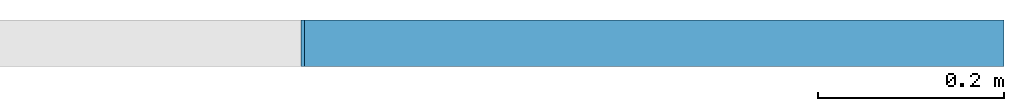
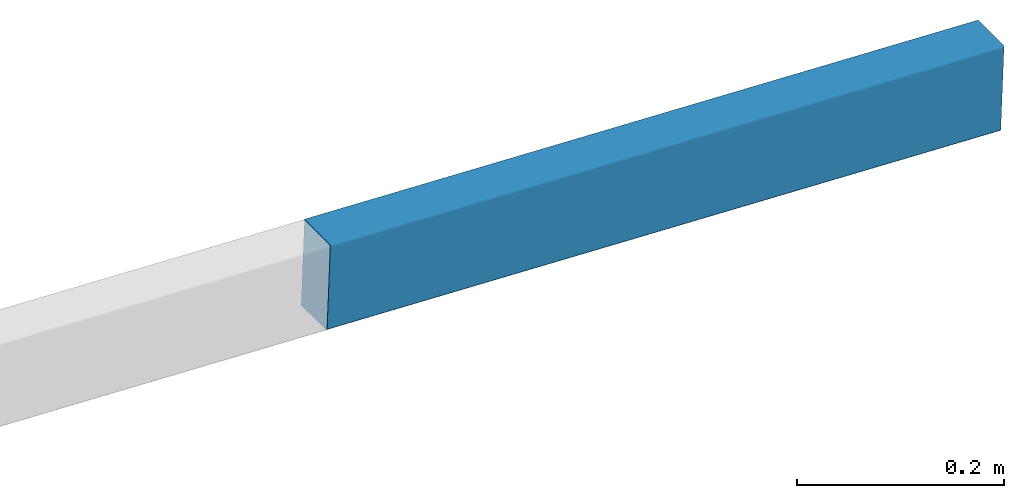
# One storey, part 2 of 2: 1 member.
"""IFC4 building model written with IfcOpenShell, lengths in metres."""

from ifc_helpers import new_model, entity, si_unit, derived_unit, frame, origin_with_axes, place, context, project, spatial, mirrored_profile, composite_profile, extrude, material, material_profile, profile_set, profile_usage, element, save


model = new_model("IFC4")

# Units and contexts
model_context = context("Model", 3, world=origin_with_axes())
ifc_project = project(units=[si_unit("LENGTHUNIT", "METRE"), si_unit("AREAUNIT", "SQUARE_METRE"), si_unit("VOLUMEUNIT", "CUBIC_METRE"), derived_unit("SECTIONMODULUSUNIT", [(si_unit("LENGTHUNIT", "METRE"), 3)]), derived_unit("MOMENTOFINERTIAUNIT", [(si_unit("LENGTHUNIT", "METRE"), 4)]), si_unit("PLANEANGLEUNIT", "RADIAN"), si_unit("TIMEUNIT", "SECOND"), si_unit("THERMODYNAMICTEMPERATUREUNIT", "DEGREE_CELSIUS"), derived_unit("THERMALEXPANSIONCOEFFICIENTUNIT", [(si_unit("THERMODYNAMICTEMPERATUREUNIT", "DEGREE_CELSIUS"), -1)])], contexts=[model_context])

# Site, building, storey
site = spatial("IfcSite", under=ifc_project, CompositionType="ELEMENT")
building = spatial("IfcBuilding", under=site, Name="Building", CompositionType="ELEMENT")
storey = spatial("IfcBuildingStorey", under=building, Name="LEVEL 4", CompositionType="ELEMENT", Elevation=6.5278)

# Member
ifc_material = material(Name="SAE 1020")
cartesian_point_1 = entity("IfcCartesianPoint", [0.0044999998, 0.050000001])
ifc_direction_1 = entity("IfcDirection", [1.0, 0.0])
cartesian_point_2 = entity("IfcCartesianPoint", [0.0015, 0.046999998])
cartesian_point_3 = entity("IfcCartesianPoint", [0.0015, -0.046999998])
cartesian_point_4 = entity("IfcCartesianPoint", [0.0044999998, -0.050000001])
cartesian_point_5 = entity("IfcCartesianPoint", [0.0044999998, 0.050000001])
ifc_direction_2 = entity("IfcDirection", [1.0, 0.0])
cartesian_point_6 = entity("IfcCartesianPoint", [0.0015, 0.046999998])
cartesian_point_7 = entity("IfcCartesianPoint", [0.0015, -0.046999998])
cartesian_point_8 = entity("IfcCartesianPoint", [0.0044999998, -0.050000001])
ifc_material_profile = material_profile(ifc_material, composite_profile([entity("IfcCenterLineProfileDef", "AREA", None, entity("IfcCompositeCurve", [entity("IfcCompositeCurveSegment", "CONTSAMEGRADIENT", True, entity("IfcPolyline", [entity("IfcCartesianPoint", [0.0515, 0.050000001]), cartesian_point_1])), entity("IfcCompositeCurveSegment", "CONTSAMEGRADIENT", True, entity("IfcTrimmedCurve", entity("IfcCircle", entity("IfcAxis2Placement2D", entity("IfcCartesianPoint", [0.0044999998, 0.047000002]), ifc_direction_1), 0.003), [cartesian_point_1], [cartesian_point_2], True, "CARTESIAN")), entity("IfcCompositeCurveSegment", "CONTSAMEGRADIENT", True, entity("IfcPolyline", [cartesian_point_2, cartesian_point_3])), entity("IfcCompositeCurveSegment", "CONTSAMEGRADIENT", True, entity("IfcTrimmedCurve", entity("IfcCircle", entity("IfcAxis2Placement2D", entity("IfcCartesianPoint", [0.0044999998, -0.047000002]), ifc_direction_1), 0.003), [cartesian_point_3], [cartesian_point_4], True, "CARTESIAN")), entity("IfcCompositeCurveSegment", "CONTSAMEGRADIENT", True, entity("IfcPolyline", [cartesian_point_4, entity("IfcCartesianPoint", [0.0515, -0.050000001])]))], "UNKNOWN"), 0.003), mirrored_profile(entity("IfcCenterLineProfileDef", "AREA", None, entity("IfcCompositeCurve", [entity("IfcCompositeCurveSegment", "CONTSAMEGRADIENT", True, entity("IfcPolyline", [entity("IfcCartesianPoint", [0.0515, 0.050000001]), cartesian_point_5])), entity("IfcCompositeCurveSegment", "CONTSAMEGRADIENT", True, entity("IfcTrimmedCurve", entity("IfcCircle", entity("IfcAxis2Placement2D", entity("IfcCartesianPoint", [0.0044999998, 0.047000002]), ifc_direction_2), 0.003), [cartesian_point_5], [cartesian_point_6], True, "CARTESIAN")), entity("IfcCompositeCurveSegment", "CONTSAMEGRADIENT", True, entity("IfcPolyline", [cartesian_point_6, cartesian_point_7])), entity("IfcCompositeCurveSegment", "CONTSAMEGRADIENT", True, entity("IfcTrimmedCurve", entity("IfcCircle", entity("IfcAxis2Placement2D", entity("IfcCartesianPoint", [0.0044999998, -0.047000002]), ifc_direction_2), 0.003), [cartesian_point_7], [cartesian_point_8], True, "CARTESIAN")), entity("IfcCompositeCurveSegment", "CONTSAMEGRADIENT", True, entity("IfcPolyline", [cartesian_point_8, entity("IfcCartesianPoint", [0.0515, -0.050000001])]))], "UNKNOWN"), 0.003))]))
ifc_profile_set = profile_set([ifc_material_profile])
ifc_profile_usage = profile_usage(ifc_profile_set, cardinal=10)
member_placement = place(None, frame((30.500014, 3.166, 6.5278), z_axis=(0.99929685, 0.0, -0.037494075), x_axis=(0.0, 1.0, 0.0)))
cartesian_point_9 = entity("IfcCartesianPoint", [0.0044999998, 0.050000001])
ifc_direction_3 = entity("IfcDirection", [1.0, 0.0])
cartesian_point_10 = entity("IfcCartesianPoint", [0.0015, 0.046999998])
cartesian_point_11 = entity("IfcCartesianPoint", [0.0015, -0.046999998])
cartesian_point_12 = entity("IfcCartesianPoint", [0.0044999998, -0.050000001])
cartesian_point_13 = entity("IfcCartesianPoint", [0.0044999998, 0.050000001])
ifc_direction_4 = entity("IfcDirection", [1.0, 0.0])
cartesian_point_14 = entity("IfcCartesianPoint", [0.0015, 0.046999998])
cartesian_point_15 = entity("IfcCartesianPoint", [0.0015, -0.046999998])
cartesian_point_16 = entity("IfcCartesianPoint", [0.0044999998, -0.050000001])
element("IfcMember", 1, at=member_placement, inside=storey, material=ifc_profile_usage, Name="1719", context=model_context, shape_type="SweptSolid", body=[
    extrude(composite_profile([entity("IfcCenterLineProfileDef", "AREA", None, entity("IfcCompositeCurve", [entity("IfcCompositeCurveSegment", "CONTSAMEGRADIENT", True, entity("IfcPolyline", [entity("IfcCartesianPoint", [0.0515, 0.050000001]), cartesian_point_9])), entity("IfcCompositeCurveSegment", "CONTSAMEGRADIENT", True, entity("IfcTrimmedCurve", entity("IfcCircle", entity("IfcAxis2Placement2D", entity("IfcCartesianPoint", [0.0044999998, 0.047000002]), ifc_direction_3), 0.003), [cartesian_point_9], [cartesian_point_10], True, "CARTESIAN")), entity("IfcCompositeCurveSegment", "CONTSAMEGRADIENT", True, entity("IfcPolyline", [cartesian_point_10, cartesian_point_11])), entity("IfcCompositeCurveSegment", "CONTSAMEGRADIENT", True, entity("IfcTrimmedCurve", entity("IfcCircle", entity("IfcAxis2Placement2D", entity("IfcCartesianPoint", [0.0044999998, -0.047000002]), ifc_direction_3), 0.003), [cartesian_point_11], [cartesian_point_12], True, "CARTESIAN")), entity("IfcCompositeCurveSegment", "CONTSAMEGRADIENT", True, entity("IfcPolyline", [cartesian_point_12, entity("IfcCartesianPoint", [0.0515, -0.050000001])]))], "UNKNOWN"), 0.003), mirrored_profile(entity("IfcCenterLineProfileDef", "AREA", None, entity("IfcCompositeCurve", [entity("IfcCompositeCurveSegment", "CONTSAMEGRADIENT", True, entity("IfcPolyline", [entity("IfcCartesianPoint", [0.0515, 0.050000001]), cartesian_point_13])), entity("IfcCompositeCurveSegment", "CONTSAMEGRADIENT", True, entity("IfcTrimmedCurve", entity("IfcCircle", entity("IfcAxis2Placement2D", entity("IfcCartesianPoint", [0.0044999998, 0.047000002]), ifc_direction_4), 0.003), [cartesian_point_13], [cartesian_point_14], True, "CARTESIAN")), entity("IfcCompositeCurveSegment", "CONTSAMEGRADIENT", True, entity("IfcPolyline", [cartesian_point_14, cartesian_point_15])), entity("IfcCompositeCurveSegment", "CONTSAMEGRADIENT", True, entity("IfcTrimmedCurve", entity("IfcCircle", entity("IfcAxis2Placement2D", entity("IfcCartesianPoint", [0.0044999998, -0.047000002]), ifc_direction_4), 0.003), [cartesian_point_15], [cartesian_point_16], True, "CARTESIAN")), entity("IfcCompositeCurveSegment", "CONTSAMEGRADIENT", True, entity("IfcPolyline", [cartesian_point_16, entity("IfcCartesianPoint", [0.0515, -0.050000001])]))], "UNKNOWN"), 0.003))]), origin_with_axes(), (0.0, 0.0, 1.0), 0.75052772),
])

save(model, "model.ifc")
